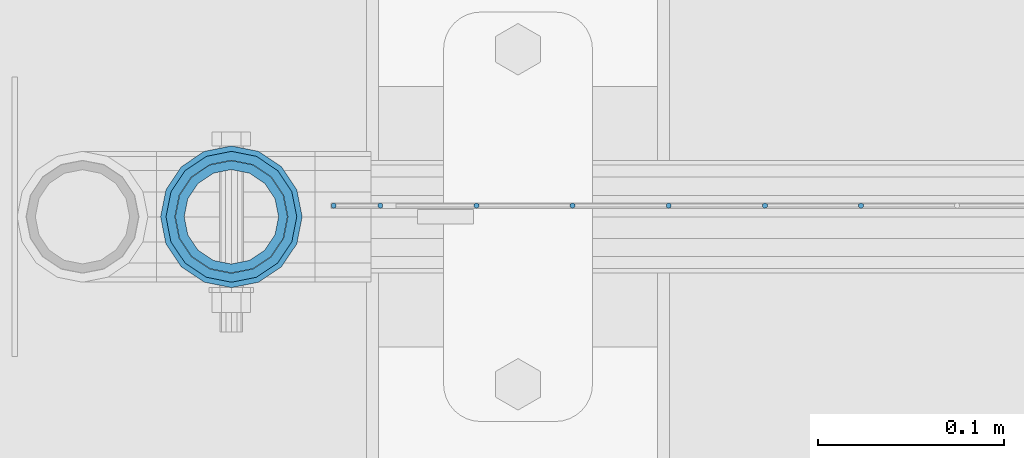
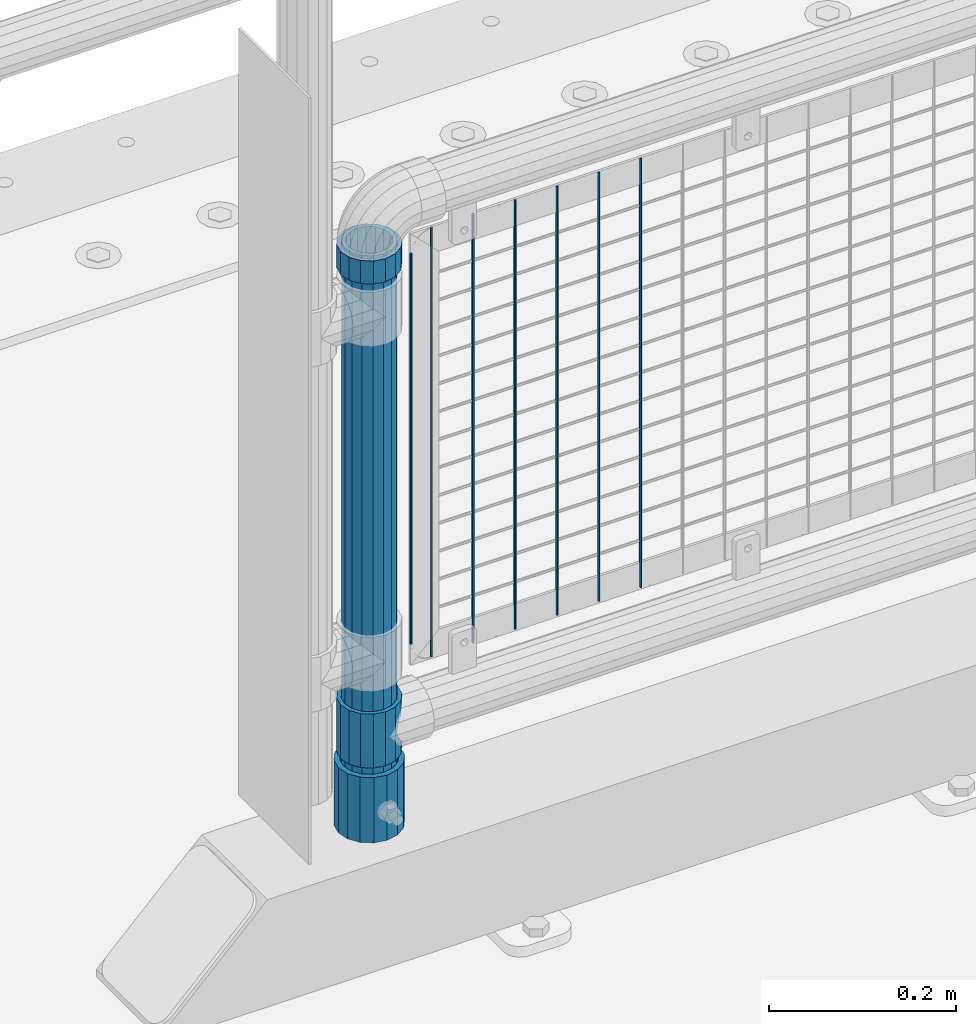
# One storey, part 66 of 240: 11 columns.
"""IFC2X3 building model written with IfcOpenShell, lengths in millimetres."""

from ifc_helpers import new_model, si_unit, frame, origin_with_axes, place, context, subcontext, project, spatial, faceted_brep, material, type_object, element, save


model = new_model("IFC2X3")

# Units and contexts
model_context = context("Model", 3, precision=1e-05, world=origin_with_axes())
body_context = subcontext(model_context, "Body", "Model", "MODEL_VIEW")
ifc_project = project(units=[si_unit("LENGTHUNIT", "METRE", prefix="MILLI"), si_unit("AREAUNIT", "SQUARE_METRE"), si_unit("VOLUMEUNIT", "CUBIC_METRE"), si_unit("MASSUNIT", "GRAM", prefix="KILO"), si_unit("TIMEUNIT", "SECOND"), si_unit("PLANEANGLEUNIT", "RADIAN"), si_unit("SOLIDANGLEUNIT", "STERADIAN"), si_unit("THERMODYNAMICTEMPERATUREUNIT", "DEGREE_CELSIUS"), si_unit("LUMINOUSINTENSITYUNIT", "LUMEN")], contexts=[model_context])

# Site, building, storey
site_placement = place(None, origin_with_axes())
site = spatial("IfcSite", under=ifc_project, at=site_placement, CompositionType="ELEMENT")
building_placement = place(site_placement, origin_with_axes())
building = spatial("IfcBuilding", under=site, at=building_placement, Name="Standard", CompositionType="ELEMENT")
storey_placement = place(building_placement, origin_with_axes())
storey = spatial("IfcBuildingStorey", under=building, at=storey_placement, Name="Undefined", CompositionType="ELEMENT", Elevation=0.0)

# Columns
ifc_material_1 = material(Name="Misc_Undefined")
column_type_1 = type_object("IfcColumnType", PredefinedType="NOTDEFINED")
column_1_placement = place(storey_placement, frame((43071.0, 34664.5, 263.52), z_axis=(-1.0, 0.0, 0.0), x_axis=(0.0, 0.0, 1.0)))
element("IfcColumn", 1, at=column_1_placement, inside=storey, type_object=column_type_1, material=ifc_material_1, context=body_context, shape_type="Brep", body=[
    faceted_brep([(56.6106908090114, 21.4606908090136, -21.4606908090136), (56.6106908090114, 21.4606908090136, -27.1226768591077), (61.9623795176703, 13.4513226476338, -32.4743655677739), (63.1897438117172, 11.6144421722784, -32.8397438117172), (63.1897438117172, 11.6144421722784, -28.0397438117143), (46.7644421722801, 28.0397438117143, -11.6144421722784), (46.7644421722801, 28.0397438117143, -20.0882031229849), (51.5310424079941, 24.8548033587067, -24.8548033587067), (35.1500000000015, 30.35, 0.0), (35.1499999999996, 30.3499999999985, -16.6306603983685), (23.5355578277192, 28.0397438117143, -11.6144421722784), (23.5355578277192, 28.0397438117143, -20.0882031229849), (13.6893091909879, 21.4606908090136, -21.4606908090136), (13.6893091909879, 21.4606908090136, -27.1226768591077), (18.7689575919921, 24.8548033587067, -24.8548033587067), (7.11025618828211, 11.6144421722784, -28.0397438117143), (7.11025618828211, 11.6144421722784, -32.8397438117172), (8.33762048232893, 13.4513226476338, -32.4743655677739), (4.79999999999961, 0.0, -30.3499999999985), (4.79999999999961, 0.0, -35.1500000000015), (7.11025618828211, -11.6144421722784, -28.0397438117143), (7.11025618828211, -11.6144421722784, -32.8397438117245), (13.6893091909879, -21.4606908090136, -21.4606908090136), (13.6893091909879, -21.4606908090136, -27.1226768591223), (8.33762048232455, -13.4513226476338, -32.4743655677739), (23.5355578277191, -28.0397438117143, -11.6144421722784), (23.5355578277191, -28.0397438117143, -20.0882031229994), (18.7689575919987, -24.8548033587067, -24.8548033587067), (35.1500000000015, -30.35, 0.0), (35.1499999999996, -30.3499999999985, -16.6306603983758), (46.7644421722801, -28.0397438117143, -11.6144421722784), (46.7644421722801, -28.0397438117143, -20.0882031229994), (56.6106908090114, -21.4606908090136, -21.4606908090136), (56.6106908090114, -21.4606908090136, -27.1226768591223), (51.5310424080006, -24.8548033587067, -24.8548033587067), (63.1897438117172, -11.6144421722784, -28.0397438117143), (63.1897438117172, -11.6144421722784, -32.8397438117245), (61.9623795176703, -13.4513226476338, -32.4743655677739), (65.4999999999997, 0.0, -30.3499999999985), (65.4999999999997, 0.0, -35.1500000000015), (70.2999999999993, -11.6144421722784, -28.0397438117143), (70.2999999999993, 0.0, -30.3499999999985), (70.2999999999993, -21.4606908090136, -21.4606908090136), (70.2999999999993, -28.0397438117143, -11.6144421722784), (70.2999999999993, -30.3499999999985, 0.0), (0.0, -28.0397438117143, -11.6144421722784), (0.0, -30.3499999999985, 0.0), (0.0, -21.4606908090136, -21.4606908090136), (0.0, -11.6144421722784, -28.0397438117143), (0.0, 0.0, -30.3499999999985), (0.0, 11.6144421722784, -28.0397438117143), (0.0, 21.4606908090136, -21.4606908090136), (0.0, 28.0397438117143, -11.6144421722784), (0.0, 30.3499999999985, 0.0), (0.0, -24.8548033587067, -24.8548033587067), (0.0, -13.4513226476338, -32.4743655677739), (0.0, 0.0, -35.1500000000015), (0.0, 13.4513226476338, -32.4743655677739), (0.0, 24.8548033587067, -24.8548033587067), (0.0, -32.4743655677739, 13.4513226476338), (0.0, -35.1500000000015, 0.0), (70.2999999999993, -35.1500000000015, 0.0), (70.2999999999993, -32.4743655677739, 13.4513226476338), (0.0, -24.8548033587067, 24.8548033587067), (70.2999999999993, -24.8548033587067, 24.8548033587067), (0.0, -13.4513226476338, 32.4743655677739), (70.2999999999993, -13.4513226476338, 32.4743655677739), (0.0, 0.0, 35.1500000000015), (70.2999999999993, 0.0, 35.1500000000015), (0.0, 13.4513226476338, 32.4743655677739), (70.2999999999993, 13.4513226476338, 32.4743655677739), (0.0, 24.8548033587067, 24.8548033587067), (70.2999999999993, 24.8548033587067, 24.8548033587067), (0.0, 32.4743655677739, 13.4513226476338), (70.2999999999993, 32.4743655677739, 13.4513226476338), (0.0, 35.1500000000015, 0.0), (70.2999999999993, 35.1500000000015, 0.0), (0.0, 32.4743655677739, -13.4513226476338), (70.2999999999993, 32.4743655677739, -13.4513226476338), (70.2999999999993, 24.8548033587067, -24.8548033587067), (70.2999999999993, 13.4513226476338, -32.4743655677739), (70.2999999999993, 0.0, -35.1500000000015), (70.2999999999993, -13.4513226476338, -32.4743655677739), (70.2999999999993, -24.8548033587067, -24.8548033587067), (70.2999999999993, -32.4743655677739, -13.4513226476338), (0.0, -32.4743655677739, -13.4513226476338), (0.0, 28.0397438117143, 11.6144421722784), (0.0, 21.4606908090136, 21.4606908090136), (0.0, 11.6144421722784, 28.0397438117143), (0.0, 0.0, 30.3499999999985), (0.0, -11.6144421722784, 28.0397438117143), (0.0, -21.4606908090136, 21.4606908090136), (0.0, -28.0397438117143, 11.6144421722784), (70.2999999999993, 28.0397438117143, 11.6144421722784), (70.2999999999993, 21.4606908090136, 21.4606908090136), (70.2999999999993, 11.6144421722784, 28.0397438117143), (70.2999999999993, 0.0, 30.3499999999985), (70.2999999999993, -11.6144421722784, 28.0397438117143), (70.2999999999993, -21.4606908090136, 21.4606908090136), (70.2999999999993, -28.0397438117143, 11.6144421722784), (70.2999999999993, 30.3499999999985, 0.0), (70.2999999999993, 28.0397438117143, -11.6144421722784), (70.2999999999993, 21.4606908090136, -21.4606908090136), (70.2999999999993, 11.6144421722784, -28.0397438117143)], [[[0, 1, 2, 3, 4]], [[5, 6, 7, 1, 0]], [[8, 9, 6, 5]], [[10, 11, 9, 8]], [[12, 13, 14, 11, 10]], [[15, 16, 17, 13, 12]], [[18, 19, 16, 15]], [[20, 21, 19, 18]], [[22, 23, 24, 21, 20]], [[25, 26, 27, 23, 22]], [[28, 29, 26, 25]], [[30, 31, 29, 28]], [[32, 33, 34, 31, 30]], [[35, 36, 37, 33, 32]], [[38, 39, 36, 35]], [[4, 3, 39, 38]], [[40, 41, 38, 35]], [[42, 40, 35, 32]], [[43, 42, 32, 30]], [[44, 43, 30, 28]], [[45, 46, 28, 25]], [[47, 45, 25, 22]], [[48, 47, 22, 20]], [[49, 48, 20, 18]], [[50, 49, 18, 15]], [[51, 50, 15, 12]], [[52, 51, 12, 10]], [[53, 52, 10, 8]], [[54, 55, 24, 23, 27]], [[55, 56, 19, 21, 24]], [[19, 56, 57, 17, 16]], [[17, 57, 58, 14, 13]], [[59, 60, 61, 62]], [[63, 59, 62, 64]], [[65, 63, 64, 66]], [[67, 65, 66, 68]], [[69, 67, 68, 70]], [[71, 69, 70, 72]], [[73, 71, 72, 74]], [[75, 73, 74, 76]], [[77, 75, 76, 78]], [[14, 58, 77, 78, 79, 7, 6, 9, 11]], [[79, 80, 2, 1, 7]], [[80, 81, 39, 3, 2]], [[37, 82, 83, 34, 33]], [[39, 81, 82, 37, 36]], [[34, 83, 84, 85, 54, 27, 26, 29, 31]], [[60, 85, 84, 61]], [[59, 63, 65, 67, 69, 71, 73, 75, 77, 58, 57, 56, 55, 54, 85, 60], [45, 47, 48, 49, 50, 51, 52, 53, 86, 87, 88, 89, 90, 91, 92, 46]], [[87, 86, 93, 94]], [[88, 87, 94, 95]], [[89, 88, 95, 96]], [[90, 89, 96, 97]], [[91, 90, 97, 98]], [[92, 91, 98, 99]], [[28, 46, 92, 99, 44]], [[83, 82, 81, 80, 79, 78, 76, 74, 72, 70, 68, 66, 64, 62, 61, 84], [98, 97, 96, 95, 94, 93, 100, 101, 102, 103, 41, 40, 42, 43, 44, 99]], [[86, 53, 8, 100, 93]], [[101, 100, 8, 5]], [[102, 101, 5, 0]], [[103, 102, 0, 4]], [[41, 103, 4, 38]]]),
])
column_2_placement = place(storey_placement, frame((43071.0, 34664.5, 894.849999999999), z_axis=(-1.0, 0.0, 0.0), x_axis=(0.0, 0.0, 1.0)))
element("IfcColumn", 2, at=column_2_placement, inside=storey, type_object=column_type_1, material=ifc_material_1, context=body_context, shape_type="Brep", body=[
    faceted_brep([(0.0, -30.3499999999985, 0.0), (0.0, -28.0397438117143, 11.6144421722784), (30.0, -28.0397438117143, 11.6144421722805), (30.0, -30.3499999999985, 0.0), (0.0, -21.4606908090136, 21.4606908090136), (30.0, -21.4606908090136, 21.4606908090117), (0.0, -11.6144421722784, 28.0397438117143), (30.0, -11.6144421722784, 28.0397438117176), (0.0, 0.0, 30.3499999999985), (30.0, 0.0, 30.35), (0.0, 11.6144421722784, 28.0397438117143), (30.0, 11.6144421722784, 28.0397438117176), (0.0, 21.4606908090136, 21.4606908090136), (30.0, 21.4606908090136, 21.4606908090117), (0.0, 28.0397438117143, 11.6144421722784), (30.0, 28.0397438117143, 11.6144421722805), (0.0, 30.3499999999985, 0.0), (30.0, 30.3499999999985, 0.0), (0.0, 28.0397438117143, -11.6144421722784), (30.0, 28.0397438117143, -11.6144421722805), (0.0, 21.4606908090136, -21.4606908090136), (30.0, 21.4606908090136, -21.4606908090117), (0.0, 11.6144421722784, -28.0397438117143), (30.0, 11.6144421722784, -28.0397438117176), (0.0, 0.0, -30.3499999999985), (30.0, 0.0, -30.35), (0.0, -11.6144421722784, -28.0397438117143), (30.0, -11.6144421722784, -28.0397438117176), (0.0, -21.4606908090136, -21.4606908090136), (30.0, -21.4606908090136, -21.4606908090117), (0.0, -28.0397438117143, -11.6144421722784), (30.0, -28.0397438117143, -11.6144421722805), (0.0, -35.1500000000015, 0.0), (0.0, -32.4743655677739, -13.4513226476338), (30.0, -32.4743655677739, -13.4513226476329), (30.0, -35.1500000000015, 0.0), (0.0, -24.8548033587067, -24.8548033587067), (30.0, -24.8548033587067, -24.8548033587072), (0.0, -13.4513226476338, -32.4743655677739), (30.0, -13.4513226476338, -32.4743655677718), (0.0, 0.0, -35.1500000000015), (30.0, 0.0, -35.15), (0.0, 13.4513226476338, -32.4743655677739), (30.0, 13.4513226476338, -32.4743655677718), (0.0, 24.8548033587067, -24.8548033587067), (30.0, 24.8548033587067, -24.8548033587072), (0.0, 32.4743655677739, -13.4513226476338), (30.0, 32.4743655677739, -13.4513226476329), (0.0, 35.1500000000015, 0.0), (30.0, 35.1500000000015, 0.0), (0.0, 32.4743655677739, 13.4513226476338), (30.0, 32.4743655677739, 13.4513226476329), (0.0, 24.8548033587067, 24.8548033587067), (30.0, 24.8548033587067, 24.8548033587072), (0.0, 13.4513226476338, 32.4743655677739), (30.0, 13.4513226476338, 32.4743655677718), (0.0, 0.0, 35.1500000000015), (30.0, 0.0, 35.15), (0.0, -13.4513226476338, 32.4743655677739), (30.0, -13.4513226476338, 32.4743655677718), (0.0, -24.8548033587067, 24.8548033587067), (30.0, -24.8548033587067, 24.8548033587072), (0.0, -32.4743655677739, 13.4513226476338), (30.0, -32.4743655677739, 13.4513226476329)], [[[0, 1, 2, 3]], [[1, 4, 5, 2]], [[4, 6, 7, 5]], [[6, 8, 9, 7]], [[8, 10, 11, 9]], [[10, 12, 13, 11]], [[12, 14, 15, 13]], [[14, 16, 17, 15]], [[16, 18, 19, 17]], [[18, 20, 21, 19]], [[20, 22, 23, 21]], [[22, 24, 25, 23]], [[24, 26, 27, 25]], [[26, 28, 29, 27]], [[28, 30, 31, 29]], [[30, 0, 3, 31]], [[32, 33, 34, 35]], [[33, 36, 37, 34]], [[36, 38, 39, 37]], [[38, 40, 41, 39]], [[40, 42, 43, 41]], [[42, 44, 45, 43]], [[44, 46, 47, 45]], [[46, 48, 49, 47]], [[48, 50, 51, 49]], [[50, 52, 53, 51]], [[52, 54, 55, 53]], [[54, 56, 57, 55]], [[56, 58, 59, 57]], [[58, 60, 61, 59]], [[60, 62, 63, 61]], [[62, 32, 35, 63]], [[37, 39, 41, 43, 45, 47, 49, 51, 53, 55, 57, 59, 61, 63, 35, 34], [5, 7, 9, 11, 13, 15, 17, 19, 21, 23, 25, 27, 29, 31, 3, 2]], [[62, 60, 58, 56, 54, 52, 50, 48, 46, 44, 42, 40, 38, 36, 33, 32], [30, 28, 26, 24, 22, 20, 18, 16, 14, 12, 10, 8, 6, 4, 1, 0]]]),
])
ifc_material_2 = material()
column_type_2 = type_object("IfcColumnType", PredefinedType="NOTDEFINED")
column_3_placement = place(storey_placement, frame((43070.9999998042, 34664.5, 168.019999999998), z_axis=(-1.0, 0.0, 0.0), x_axis=(0.0, 0.0, 1.0)))
element("IfcColumn", 3, at=column_3_placement, inside=storey, type_object=column_type_2, material=ifc_material_2, context=body_context, shape_type="Brep", body=[
    faceted_brep([(0.0, -25.3499999999985, 0.0), (0.0, -23.4203461491634, 9.70102501045767), (760.0, -23.4203461491634, 9.70102501045767), (760.0, -25.3499999999985, 0.0), (0.0, -17.9251569030821, 17.9251569030821), (760.0, -17.9251569030821, 17.9251569030821), (0.0, -9.70102501045767, 23.4203461491634), (760.0, -9.70102501045767, 23.4203461491634), (0.0, 0.0, 25.3499999999985), (760.0, 0.0, 25.3499999999985), (0.0, 9.70102501045767, 23.4203461491634), (760.0, 9.70102501045767, 23.4203461491634), (0.0, 17.9251569030821, 17.9251569030821), (760.0, 17.9251569030821, 17.9251569030821), (0.0, 23.4203461491634, 9.70102501045767), (760.0, 23.4203461491634, 9.70102501045767), (0.0, 25.3499999999985, 0.0), (760.0, 25.3499999999985, 0.0), (0.0, 23.4203461491634, -9.70102501045767), (760.0, 23.4203461491634, -9.70102501045767), (0.0, 17.9251569030821, -17.9251569030821), (760.0, 17.9251569030821, -17.9251569030821), (0.0, 9.70102501045767, -23.4203461491634), (760.0, 9.70102501045767, -23.4203461491634), (0.0, 0.0, -25.3499999999985), (760.0, 0.0, -25.3499999999985), (0.0, -9.70102501045767, -23.4203461491634), (760.0, -9.70102501045767, -23.4203461491634), (0.0, -17.9251569030821, -17.9251569030821), (760.0, -17.9251569030821, -17.9251569030821), (0.0, -23.4203461491634, -9.70102501045767), (760.0, -23.4203461491634, -9.70102501045767), (0.0, -30.1500000000015, 0.0), (0.0, -27.8549679052157, -11.5379054858058), (760.0, -27.8549679052157, -11.5379054858058), (760.0, -30.1500000000015, 0.0), (0.0, -21.3192694527752, -21.3192694527752), (760.0, -21.3192694527752, -21.3192694527752), (0.0, -11.5379054858058, -27.8549679052157), (760.0, -11.5379054858058, -27.8549679052157), (0.0, 0.0, -30.1500000000015), (760.0, 0.0, -30.1500000000015), (0.0, 11.5379054858058, -27.8549679052157), (760.0, 11.5379054858058, -27.8549679052157), (0.0, 21.3192694527752, -21.3192694527752), (760.0, 21.3192694527752, -21.3192694527752), (0.0, 27.8549679052157, -11.5379054858058), (760.0, 27.8549679052157, -11.5379054858058), (0.0, 30.1500000000015, 0.0), (760.0, 30.1500000000015, 0.0), (0.0, 27.8549679052157, 11.5379054858058), (760.0, 27.8549679052157, 11.5379054858058), (0.0, 21.3192694527752, 21.3192694527752), (760.0, 21.3192694527752, 21.3192694527752), (0.0, 11.5379054858058, 27.8549679052157), (760.0, 11.5379054858058, 27.8549679052157), (0.0, 0.0, 30.1500000000015), (760.0, 0.0, 30.1500000000015), (0.0, -11.5379054858058, 27.8549679052157), (760.0, -11.5379054858058, 27.8549679052157), (0.0, -21.3192694527752, 21.3192694527752), (760.0, -21.3192694527752, 21.3192694527752), (0.0, -27.8549679052157, 11.5379054858058), (760.0, -27.8549679052157, 11.5379054858058)], [[[0, 1, 2, 3]], [[1, 4, 5, 2]], [[4, 6, 7, 5]], [[6, 8, 9, 7]], [[8, 10, 11, 9]], [[10, 12, 13, 11]], [[12, 14, 15, 13]], [[14, 16, 17, 15]], [[16, 18, 19, 17]], [[18, 20, 21, 19]], [[20, 22, 23, 21]], [[22, 24, 25, 23]], [[24, 26, 27, 25]], [[26, 28, 29, 27]], [[28, 30, 31, 29]], [[30, 0, 3, 31]], [[32, 33, 34, 35]], [[33, 36, 37, 34]], [[36, 38, 39, 37]], [[38, 40, 41, 39]], [[40, 42, 43, 41]], [[42, 44, 45, 43]], [[44, 46, 47, 45]], [[46, 48, 49, 47]], [[48, 50, 51, 49]], [[50, 52, 53, 51]], [[52, 54, 55, 53]], [[54, 56, 57, 55]], [[56, 58, 59, 57]], [[58, 60, 61, 59]], [[60, 62, 63, 61]], [[62, 32, 35, 63]], [[37, 39, 41, 43, 45, 47, 49, 51, 53, 55, 57, 59, 61, 63, 35, 34], [5, 7, 9, 11, 13, 15, 17, 19, 21, 23, 25, 27, 29, 31, 3, 2]], [[62, 60, 58, 56, 54, 52, 50, 48, 46, 44, 42, 40, 38, 36, 33, 32], [30, 28, 26, 24, 22, 20, 18, 16, 14, 12, 10, 8, 6, 4, 1, 0]]]),
])
column_type_3 = type_object("IfcColumnType", Name="D3", PredefinedType="NOTDEFINED")
for number, where, z_axis, x_axis in (
    (4, (43409.275, 34670.5, 353.02), (-1.0, 0.0, 0.0), (0.0, 0.0, 1.0)),
    (5, (43357.62, 34670.5, 353.02), (-1.0, 0.0, 0.0), (0.0, 0.0, 1.0)),
    (6, (43305.965, 34670.5, 353.02), (-1.0, 0.0, 0.0), (0.0, 0.0, 1.0)),
    (7, (43254.31, 34670.5, 353.02), (-1.0, 0.0, 0.0), (0.0, 0.0, 1.0)),
    (8, (43202.655, 34670.5, 353.02), (-1.0, 0.0, 0.0), (0.0, 0.0, 1.0)),
):
    element("IfcColumn", number, at=place(storey_placement, frame(where, z_axis=z_axis, x_axis=x_axis)), inside=storey, type_object=column_type_3, material=ifc_material_1, ObjectType="D3", context=body_context, shape_type="Brep", body=[
        faceted_brep([(-7.27595761418343e-12, -1.49999999999272, 0.0), (-7.27595761418343e-12, -0.749999999992724, -1.29903810567669), (560.0, -0.75, -1.29903810567339), (560.0, -1.5, 0.0), (0.0, 0.750000000007276, -1.29903810567669), (560.0, 0.75, -1.29903810567339), (0.0, 1.50000000000728, 0.0), (560.0, 1.5, 0.0), (0.0, 0.750000000007276, 1.29903810567669), (560.0, 0.75, 1.29903810567339), (-7.27595761418343e-12, -0.749999999992724, 1.29903810567669), (560.0, -0.75, 1.29903810567339)], [[[0, 1, 2, 3]], [[1, 4, 5, 2]], [[4, 6, 7, 5]], [[6, 8, 9, 7]], [[8, 10, 11, 9]], [[10, 0, 3, 11]], [[5, 7, 9, 11, 3, 2]], [[10, 8, 6, 4, 1, 0]]]),
    ])
column_4_placement = place(storey_placement, frame((43126.0, 34670.5, 378.02), z_axis=(-1.0, 0.0, 0.0), x_axis=(0.0, 0.0, 1.0)))
element("IfcColumn", 9, at=column_4_placement, inside=storey, type_object=column_type_3, material=ifc_material_1, ObjectType="D3", context=body_context, shape_type="Brep", body=[
    faceted_brep([(-7.27595761418343e-12, -1.49999999999272, 0.0), (-7.27595761418343e-12, -0.749999999992724, -1.29903810567669), (510.0, -0.75, -1.29903810567339), (510.0, -1.5, 0.0), (0.0, 0.750000000007276, -1.29903810567669), (510.0, 0.75, -1.29903810567339), (0.0, 1.50000000000728, 0.0), (510.0, 1.5, 0.0), (0.0, 0.750000000007276, 1.29903810567669), (510.0, 0.75, 1.29903810567339), (-7.27595761418343e-12, -0.749999999992724, 1.29903810567669), (510.0, -0.75, 1.29903810567339)], [[[0, 1, 2, 3]], [[1, 4, 5, 2]], [[4, 6, 7, 5]], [[6, 8, 9, 7]], [[8, 10, 11, 9]], [[10, 0, 3, 11]], [[5, 7, 9, 11, 3, 2]], [[10, 8, 6, 4, 1, 0]]]),
])
column_5_placement = place(storey_placement, frame((43151.0, 34670.5, 353.02), z_axis=(-1.0, 0.0, 0.0), x_axis=(0.0, 0.0, 1.0)))
element("IfcColumn", 10, at=column_5_placement, inside=storey, type_object=column_type_3, material=ifc_material_1, ObjectType="D3", context=body_context, shape_type="Brep", body=[
    faceted_brep([(-7.27595761418343e-12, -1.49999999999272, 0.0), (-7.27595761418343e-12, -0.749999999992724, -1.29903810567669), (560.0, -0.75, -1.29903810567339), (560.0, -1.5, 0.0), (0.0, 0.750000000007276, -1.29903810567669), (560.0, 0.75, -1.29903810567339), (0.0, 1.50000000000728, 0.0), (560.0, 1.5, 0.0), (0.0, 0.750000000007276, 1.29903810567669), (560.0, 0.75, 1.29903810567339), (-7.27595761418343e-12, -0.749999999992724, 1.29903810567669), (560.0, -0.75, 1.29903810567339)], [[[0, 1, 2, 3]], [[1, 4, 5, 2]], [[4, 6, 7, 5]], [[6, 8, 9, 7]], [[8, 10, 11, 9]], [[10, 0, 3, 11]], [[5, 7, 9, 11, 3, 2]], [[10, 8, 6, 4, 1, 0]]]),
])
column_type_4 = type_object("IfcColumnType", PredefinedType="NOTDEFINED")
column_6_placement = place(storey_placement, frame((43070.9999998042, 34664.5, 168.019999999998), z_axis=(0.0, 1.0, 0.0), x_axis=(0.0, 0.0, 1.0)))
element("IfcColumn", 11, at=column_6_placement, inside=storey, type_object=column_type_4, material=ifc_material_2, context=body_context, shape_type="Brep", body=[
    faceted_brep([(0.0, -31.75, 0.0), (0.0, -29.3331751572332, 12.1501989775934), (85.0, -29.3331751572332, 12.1501989775934), (85.0, -31.75, 0.0), (0.0, -22.4506403026753, 22.4506403026753), (85.0, -22.4506403026753, 22.4506403026753), (0.0, -12.1501989775934, 29.3331751572332), (85.0, -12.1501989775934, 29.3331751572332), (0.0, 0.0, 31.75), (85.0, 0.0, 31.75), (0.0, 12.1501989775934, 29.3331751572332), (85.0, 12.1501989775934, 29.3331751572332), (0.0, 22.4506403026753, 22.4506403026753), (85.0, 22.4506403026753, 22.4506403026753), (0.0, 29.3331751572332, 12.1501989775934), (85.0, 29.3331751572332, 12.1501989775934), (0.0, 31.75, 0.0), (85.0, 31.75, 0.0), (0.0, 29.3331751572332, -12.1501989775934), (85.0, 29.3331751572332, -12.1501989775934), (0.0, 22.4506403026753, -22.4506403026753), (85.0, 22.4506403026753, -22.4506403026753), (0.0, 12.1501989775934, -29.3331751572332), (85.0, 12.1501989775934, -29.3331751572332), (0.0, 0.0, -31.75), (85.0, 0.0, -31.75), (0.0, -12.1501989775934, -29.3331751572332), (85.0, -12.1501989775934, -29.3331751572332), (0.0, -22.4506403026753, -22.4506403026753), (85.0, -22.4506403026753, -22.4506403026753), (0.0, -29.3331751572332, -12.1501989775934), (85.0, -29.3331751572332, -12.1501989775934), (0.0, -38.0500000000029, 0.0), (0.0, -35.1536162120537, -14.5611046014892), (85.0, -35.1536162120537, -14.5611046014892), (85.0, -38.0500000000029, 0.0), (0.0, -26.9054130241493, -26.9054130241493), (85.0, -26.9054130241493, -26.9054130241493), (0.0, -14.5611046014892, -35.1536162120537), (85.0, -14.5611046014892, -35.1536162120537), (0.0, 0.0, -38.0500000000029), (85.0, 0.0, -38.0500000000029), (0.0, 14.5611046014892, -35.1536162120537), (85.0, 14.5611046014892, -35.1536162120537), (0.0, 26.9054130241493, -26.9054130241493), (85.0, 26.9054130241493, -26.9054130241493), (0.0, 35.1536162120537, -14.5611046014892), (85.0, 35.1536162120537, -14.5611046014892), (0.0, 38.0500000000029, 0.0), (85.0, 38.0500000000029, 0.0), (0.0, 35.1536162120537, 14.5611046014892), (85.0, 35.1536162120537, 14.5611046014892), (0.0, 26.9054130241493, 26.9054130241493), (85.0, 26.9054130241493, 26.9054130241493), (0.0, 14.5611046014892, 35.1536162120537), (85.0, 14.5611046014892, 35.1536162120537), (0.0, 0.0, 38.0500000000029), (85.0, 0.0, 38.0500000000029), (0.0, -14.5611046014892, 35.1536162120537), (85.0, -14.5611046014892, 35.1536162120537), (0.0, -26.9054130241493, 26.9054130241493), (85.0, -26.9054130241493, 26.9054130241493), (0.0, -35.1536162120537, 14.5611046014892), (85.0, -35.1536162120537, 14.5611046014892)], [[[0, 1, 2, 3]], [[1, 4, 5, 2]], [[4, 6, 7, 5]], [[6, 8, 9, 7]], [[8, 10, 11, 9]], [[10, 12, 13, 11]], [[12, 14, 15, 13]], [[14, 16, 17, 15]], [[16, 18, 19, 17]], [[18, 20, 21, 19]], [[20, 22, 23, 21]], [[22, 24, 25, 23]], [[24, 26, 27, 25]], [[26, 28, 29, 27]], [[28, 30, 31, 29]], [[30, 0, 3, 31]], [[32, 33, 34, 35]], [[33, 36, 37, 34]], [[36, 38, 39, 37]], [[38, 40, 41, 39]], [[40, 42, 43, 41]], [[42, 44, 45, 43]], [[44, 46, 47, 45]], [[46, 48, 49, 47]], [[48, 50, 51, 49]], [[50, 52, 53, 51]], [[52, 54, 55, 53]], [[54, 56, 57, 55]], [[56, 58, 59, 57]], [[58, 60, 61, 59]], [[60, 62, 63, 61]], [[62, 32, 35, 63]], [[37, 39, 41, 43, 45, 47, 49, 51, 53, 55, 57, 59, 61, 63, 35, 34], [5, 7, 9, 11, 13, 15, 17, 19, 21, 23, 25, 27, 29, 31, 3, 2]], [[62, 60, 58, 56, 54, 52, 50, 48, 46, 44, 42, 40, 38, 36, 33, 32], [30, 28, 26, 24, 22, 20, 18, 16, 14, 12, 10, 8, 6, 4, 1, 0]]]),
])

save(model, "model.ifc")
